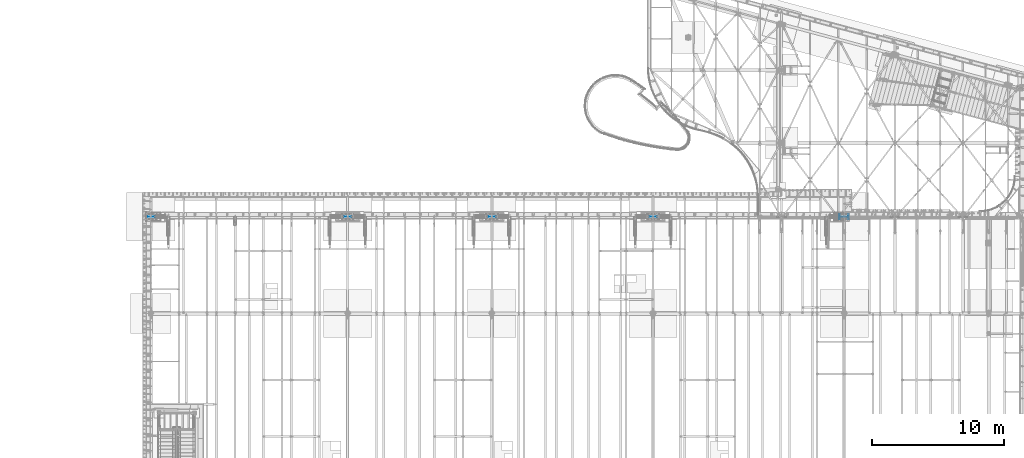
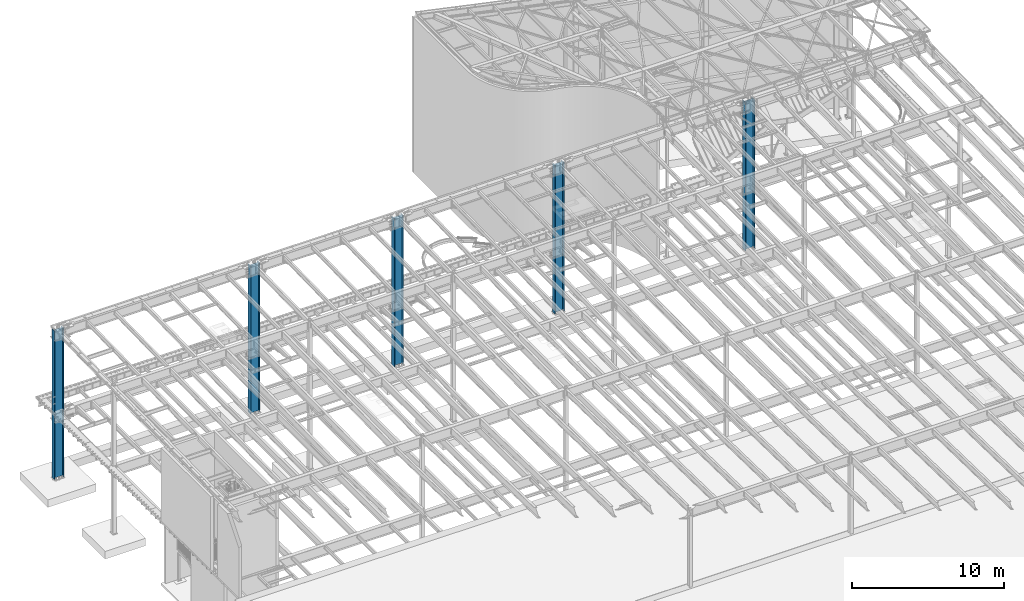
# One storey, part 913 of 1763: 5 columns, 5 elements without a shape of their own.
"""IFC2X3 building model written with IfcOpenShell, lengths in millimetres."""

from ifc_helpers import new_model, si_unit, frame, origin_with_axes, place, context, subcontext, project, spatial, faceted_brep, material, type_object, element, aggregate, save


model = new_model("IFC2X3")

# Units and contexts
model_context = context("Model", 3, precision=1e-05, world=origin_with_axes())
body_context = subcontext(model_context, "Body", "Model", "MODEL_VIEW")
ifc_project = project(units=[si_unit("LENGTHUNIT", "METRE", prefix="MILLI"), si_unit("AREAUNIT", "SQUARE_METRE"), si_unit("VOLUMEUNIT", "CUBIC_METRE"), si_unit("MASSUNIT", "GRAM", prefix="KILO"), si_unit("TIMEUNIT", "SECOND"), si_unit("PLANEANGLEUNIT", "RADIAN"), si_unit("SOLIDANGLEUNIT", "STERADIAN"), si_unit("THERMODYNAMICTEMPERATUREUNIT", "DEGREE_CELSIUS"), si_unit("LUMINOUSINTENSITYUNIT", "LUMEN")], contexts=[model_context])

# Site, building, storey
site_placement = place(None, origin_with_axes())
site = spatial("IfcSite", under=ifc_project, at=site_placement, CompositionType="ELEMENT")
building_placement = place(site_placement, origin_with_axes())
building = spatial("IfcBuilding", under=site, at=building_placement, Name="Undefined", CompositionType="ELEMENT")
storey_placement = place(building_placement, origin_with_axes())
storey = spatial("IfcBuildingStorey", under=building, at=storey_placement, Name="Undefined", CompositionType="ELEMENT", Elevation=0.0)

# Assembly, column
assembly_1_placement = place(storey_placement, origin_with_axes())
assembly_1 = element("IfcElementAssembly", 1, at=assembly_1_placement, inside=storey, Name="COLUMN", AssemblyPlace="NOTDEFINED", PredefinedType="RIGID_FRAME")
ifc_material = material(Name="STEEL/A992")
column_type = type_object("IfcColumnType", Name="W27X194", PredefinedType="NOTDEFINED")
column_1_placement = place(assembly_1_placement, frame((-34949.8372736984, 52120.8, -304.8), z_axis=(-1.0, 0.0, 0.0), x_axis=(0.0, 0.0, 1.0)))
column_1 = element("IfcColumn", 2, at=column_1_placement, type_object=column_type, material=ifc_material, Name="COLUMN", ObjectType="W27X194", context=body_context, shape_type="Brep", body=[
    faceted_brep([(12023.7249917654, -177.800000000003, 357.1875), (12023.7249917654, -177.800000000003, 323.849999999999), (12023.7249917654, -9.52500000000146, 323.850000002378), (12023.7249917654, -9.52500000000146, -323.849999999999), (12023.7249917654, -177.800000000003, -323.849999999999), (12023.7249917654, -177.800000000003, -357.1875), (12023.7249917654, 177.800000000003, -357.1875), (12023.7249917654, 177.800000000003, -323.849999999999), (12023.7249917654, 9.52500000000146, -323.849999999999), (12023.7249917654, 9.52500000000146, 323.849999999999), (12023.7249917654, 177.800000000003, 323.849999999999), (12023.7249917654, 177.800000000003, 357.1875), (88.9000000000026, 177.800000000003, -323.849999999999), (108.14741549571, 177.800000000003, -357.1875), (108.147415495711, -177.800000000003, -357.1875), (88.9000000000026, -177.800000000003, -323.849999999999), (88.9000000000026, -9.52500000000146, -323.849999999999), (88.9000000000026, 9.52500000000146, -323.849999999999), (133.350001510695, -9.52500000000146, -323.849999999999), (133.350001510695, 9.52500000000146, -323.849999999999), (133.350001231294, -9.52500000000146, -311.149997345012), (133.350001231294, 9.52500000000146, -311.149997345012), (131.416541172274, -9.52500000000146, -301.429838351462), (131.416541172274, 9.52500000000146, -301.429838351462), (125.91051319003, -9.52500000000146, -293.189485536299), (125.91051319003, 9.52500000000146, -293.189485536299), (117.670160132589, -9.52500000000146, -287.683457916653), (117.670160132589, 9.52500000000146, -287.683457916653), (107.950001053962, -9.52500000000146, -285.749998285348), (107.950001053962, 9.52500000000146, -285.749998285348), (88.9000000000026, 9.52500000000146, -285.749998704494), (107.949999754769, -9.52500000000146, 285.749998704487), (88.9000000000026, 9.52500000000146, 285.749998704487), (107.950001892185, 9.52500000000146, 285.749998704487), (117.670160928276, -9.52500000000146, 287.683458549662), (117.670160928276, 9.52500000000146, 287.683458549662), (125.910513864584, -9.52500000000146, 293.189486350617), (125.910513864584, 9.52500000000146, 293.189486350617), (131.41654166554, -9.52500000000146, 301.429839286924), (131.41654166554, 9.52500000000146, 301.429839286924), (133.350001510715, -9.52500000000146, 311.149998323017), (133.350001510715, 9.52500000000146, 311.149998323017), (133.350001510715, -9.52500000000146, 323.850000993305), (133.350001510715, 9.52500000000146, 323.849999999999), (88.9000000000026, -9.52500000000146, 323.849999999999), (88.9000000000026, 9.52500000000146, 323.849999999999), (88.9000000000026, -177.800000000003, 323.849999999999), (108.147415495711, -177.800000000003, 357.1875), (108.14741549571, 177.800000000003, 357.1875), (88.9000000000026, 177.800000000003, 323.849999999999), (133.350001510715, 177.800000000003, 323.849999999999), (133.350001510695, 177.800000000003, -323.849999999999), (133.350001510695, -177.800000000003, -323.849999999999), (133.350001510715, -177.800000000003, 323.849999999999)], [[[0, 1, 2, 3, 4, 5, 6, 7, 8, 9, 10, 11]], [[12, 13, 14, 15, 16, 17]], [[18, 19, 17, 16]], [[20, 21, 19, 18]], [[22, 23, 21, 20]], [[24, 25, 23, 22]], [[26, 27, 25, 24]], [[28, 29, 27, 26]], [[29, 28, 30]], [[31, 32, 30, 28]], [[33, 32, 31]], [[34, 35, 33, 31]], [[36, 37, 35, 34]], [[38, 39, 37, 36]], [[40, 41, 39, 38]], [[42, 43, 41, 40]], [[44, 45, 43, 42]], [[46, 47, 48, 49, 45, 44]], [[48, 47, 0, 11]], [[50, 49, 48, 11, 10]], [[43, 45, 49, 50, 10, 9]], [[19, 21, 23, 25, 27, 29, 30, 32, 33, 35, 37, 39, 41, 43, 9, 8]], [[51, 12, 17, 19, 8, 7]], [[13, 12, 51, 7, 6]], [[14, 13, 6, 5]], [[52, 15, 14, 5, 4]], [[18, 16, 15, 52, 4, 3]], [[42, 40, 38, 36, 34, 31, 28, 26, 24, 22, 20, 18, 3, 2]], [[53, 46, 44, 42, 2, 1]], [[47, 46, 53, 1, 0]]]),
])
aggregate(assembly_1, [column_1])

assembly_2_placement = place(storey_placement, origin_with_axes())
assembly_2 = element("IfcElementAssembly", 3, at=assembly_2_placement, inside=storey, Name="COLUMN", AssemblyPlace="NOTDEFINED", PredefinedType="RIGID_FRAME")
column_2_placement = place(assembly_2_placement, frame((-49402.4372736984, 52120.8, -304.8), z_axis=(-1.0, 0.0, 0.0), x_axis=(0.0, 0.0, 1.0)))
column_2 = element("IfcColumn", 4, at=column_2_placement, type_object=column_type, material=ifc_material, Name="COLUMN", ObjectType="W27X194", context=body_context, shape_type="Brep", body=[
    faceted_brep([(12023.7249917654, -177.800000000003, 357.1875), (12023.7249917654, -177.800000000003, 323.849999999999), (12023.7249917654, -9.52500000000146, 323.850000002378), (12023.7249917654, -9.52500000000146, -323.849999999999), (12023.7249917654, -177.800000000003, -323.849999999999), (12023.7249917654, -177.800000000003, -357.1875), (12023.7249917654, 177.800000000003, -357.1875), (12023.7249917654, 177.800000000003, -323.849999999999), (12023.7249917654, 9.52500000000146, -323.849999999999), (12023.7249917654, 9.52500000000146, 323.849999999999), (12023.7249917654, 177.800000000003, 323.849999999999), (12023.7249917654, 177.800000000003, 357.1875), (88.9000000000026, 177.800000000003, -323.849999999999), (108.14741549571, 177.800000000003, -357.1875), (108.147415495711, -177.800000000003, -357.1875), (88.9000000000026, -177.800000000003, -323.849999999999), (88.9000000000026, -9.52500000000146, -323.849999999999), (88.9000000000026, 9.52500000000146, -323.849999999999), (133.350001510695, -9.52500000000146, -323.849999999999), (133.350001510695, 9.52500000000146, -323.849999999999), (133.350001231294, -9.52500000000146, -311.149997345012), (133.350001231294, 9.52500000000146, -311.149997345012), (131.416541172274, -9.52500000000146, -301.429838351462), (131.416541172274, 9.52500000000146, -301.429838351462), (125.91051319003, -9.52500000000146, -293.189485536299), (125.91051319003, 9.52500000000146, -293.189485536299), (117.670160132589, -9.52500000000146, -287.683457916653), (117.670160132589, 9.52500000000146, -287.683457916653), (107.950001053962, -9.52500000000146, -285.749998285348), (107.950001053962, 9.52500000000146, -285.749998285348), (88.9000000000026, 9.52500000000146, -285.749998704494), (107.949999754769, -9.52500000000146, 285.749998704487), (88.9000000000026, 9.52500000000146, 285.749998704487), (107.950001892185, 9.52500000000146, 285.749998704487), (117.670160928276, -9.52500000000146, 287.683458549662), (117.670160928276, 9.52500000000146, 287.683458549662), (125.910513864584, -9.52500000000146, 293.189486350617), (125.910513864584, 9.52500000000146, 293.189486350617), (131.41654166554, -9.52500000000146, 301.429839286924), (131.41654166554, 9.52500000000146, 301.429839286924), (133.350001510715, -9.52500000000146, 311.149998323017), (133.350001510715, 9.52500000000146, 311.149998323017), (133.350001510715, -9.52500000000146, 323.850000993305), (133.350001510715, 9.52500000000146, 323.849999999999), (88.9000000000026, -9.52500000000146, 323.849999999999), (88.9000000000026, 9.52500000000146, 323.849999999999), (88.9000000000026, -177.800000000003, 323.849999999999), (108.147415495711, -177.800000000003, 357.1875), (108.14741549571, 177.800000000003, 357.1875), (88.9000000000026, 177.800000000003, 323.849999999999), (133.350001510715, 177.800000000003, 323.849999999999), (133.350001510695, 177.800000000003, -323.849999999999), (133.350001510695, -177.800000000003, -323.849999999999), (133.350001510715, -177.800000000003, 323.849999999999)], [[[0, 1, 2, 3, 4, 5, 6, 7, 8, 9, 10, 11]], [[12, 13, 14, 15, 16, 17]], [[18, 19, 17, 16]], [[20, 21, 19, 18]], [[22, 23, 21, 20]], [[24, 25, 23, 22]], [[26, 27, 25, 24]], [[28, 29, 27, 26]], [[29, 28, 30]], [[31, 32, 30, 28]], [[33, 32, 31]], [[34, 35, 33, 31]], [[36, 37, 35, 34]], [[38, 39, 37, 36]], [[40, 41, 39, 38]], [[42, 43, 41, 40]], [[44, 45, 43, 42]], [[46, 47, 48, 49, 45, 44]], [[48, 47, 0, 11]], [[50, 49, 48, 11, 10]], [[43, 45, 49, 50, 10, 9]], [[19, 21, 23, 25, 27, 29, 30, 32, 33, 35, 37, 39, 41, 43, 9, 8]], [[51, 12, 17, 19, 8, 7]], [[13, 12, 51, 7, 6]], [[14, 13, 6, 5]], [[52, 15, 14, 5, 4]], [[18, 16, 15, 52, 4, 3]], [[42, 40, 38, 36, 34, 31, 28, 26, 24, 22, 20, 18, 3, 2]], [[53, 46, 44, 42, 2, 1]], [[47, 46, 53, 1, 0]]]),
])
aggregate(assembly_2, [column_2])

assembly_3_placement = place(storey_placement, origin_with_axes())
assembly_3 = element("IfcElementAssembly", 5, at=assembly_3_placement, inside=storey, Name="COLUMN", AssemblyPlace="NOTDEFINED", PredefinedType="RIGID_FRAME")
column_3_placement = place(assembly_3_placement, frame((-61594.4372736983, 52120.8, -304.8), z_axis=(-1.0, 0.0, 0.0), x_axis=(0.0, 0.0, 1.0)))
column_3 = element("IfcColumn", 6, at=column_3_placement, type_object=column_type, material=ifc_material, Name="COLUMN", ObjectType="W27X194", context=body_context, shape_type="Brep", body=[
    faceted_brep([(12023.7249917654, -177.800000000003, 357.1875), (12023.7249917654, -177.800000000003, 323.849999999999), (12023.7249917654, -9.52500000000146, 323.850000002378), (12023.7249917654, -9.52500000000146, -323.849999999999), (12023.7249917654, -177.800000000003, -323.849999999999), (12023.7249917654, -177.800000000003, -357.1875), (12023.7249917654, 177.800000000003, -357.1875), (12023.7249917654, 177.800000000003, -323.849999999999), (12023.7249917654, 9.52500000000146, -323.849999999999), (12023.7249917654, 9.52500000000146, 323.849999999999), (12023.7249917654, 177.800000000003, 323.849999999999), (12023.7249917654, 177.800000000003, 357.1875), (88.9000000000026, 177.800000000003, -323.849999999999), (108.14741549571, 177.800000000003, -357.1875), (108.147415495711, -177.800000000003, -357.1875), (88.9000000000026, -177.800000000003, -323.849999999999), (88.9000000000026, -9.52500000000146, -323.849999999999), (88.9000000000026, 9.52500000000146, -323.849999999999), (133.350001510695, -9.52500000000146, -323.849999999999), (133.350001510695, 9.52500000000146, -323.849999999999), (133.350001231294, -9.52500000000146, -311.149997345012), (133.350001231294, 9.52500000000146, -311.149997345012), (131.416541172274, -9.52500000000146, -301.429838351462), (131.416541172274, 9.52500000000146, -301.429838351462), (125.91051319003, -9.52500000000146, -293.189485536299), (125.91051319003, 9.52500000000146, -293.189485536299), (117.670160132589, -9.52500000000146, -287.683457916653), (117.670160132589, 9.52500000000146, -287.683457916653), (107.950001053962, -9.52500000000146, -285.749998285348), (107.950001053962, 9.52500000000146, -285.749998285348), (88.9000000000026, 9.52500000000146, -285.749998704494), (107.949999754769, -9.52500000000146, 285.749998704487), (88.9000000000026, 9.52500000000146, 285.749998704487), (107.950001892185, 9.52500000000146, 285.749998704487), (117.670160928276, -9.52500000000146, 287.683458549662), (117.670160928276, 9.52500000000146, 287.683458549662), (125.910513864584, -9.52500000000146, 293.189486350617), (125.910513864584, 9.52500000000146, 293.189486350617), (131.41654166554, -9.52500000000146, 301.429839286924), (131.41654166554, 9.52500000000146, 301.429839286924), (133.350001510715, -9.52500000000146, 311.149998323017), (133.350001510715, 9.52500000000146, 311.149998323017), (133.350001510715, -9.52500000000146, 323.850000993305), (133.350001510715, 9.52500000000146, 323.849999999999), (88.9000000000026, -9.52500000000146, 323.849999999999), (88.9000000000026, 9.52500000000146, 323.849999999999), (88.9000000000026, -177.800000000003, 323.849999999999), (108.147415495711, -177.800000000003, 357.1875), (108.14741549571, 177.800000000003, 357.1875), (88.9000000000026, 177.800000000003, 323.849999999999), (133.350001510715, 177.800000000003, 323.849999999999), (133.350001510695, 177.800000000003, -323.849999999999), (133.350001510695, -177.800000000003, -323.849999999999), (133.350001510715, -177.800000000003, 323.849999999999)], [[[0, 1, 2, 3, 4, 5, 6, 7, 8, 9, 10, 11]], [[12, 13, 14, 15, 16, 17]], [[18, 19, 17, 16]], [[20, 21, 19, 18]], [[22, 23, 21, 20]], [[24, 25, 23, 22]], [[26, 27, 25, 24]], [[28, 29, 27, 26]], [[29, 28, 30]], [[31, 32, 30, 28]], [[33, 32, 31]], [[34, 35, 33, 31]], [[36, 37, 35, 34]], [[38, 39, 37, 36]], [[40, 41, 39, 38]], [[42, 43, 41, 40]], [[44, 45, 43, 42]], [[46, 47, 48, 49, 45, 44]], [[48, 47, 0, 11]], [[50, 49, 48, 11, 10]], [[43, 45, 49, 50, 10, 9]], [[19, 21, 23, 25, 27, 29, 30, 32, 33, 35, 37, 39, 41, 43, 9, 8]], [[51, 12, 17, 19, 8, 7]], [[13, 12, 51, 7, 6]], [[14, 13, 6, 5]], [[52, 15, 14, 5, 4]], [[18, 16, 15, 52, 4, 3]], [[42, 40, 38, 36, 34, 31, 28, 26, 24, 22, 20, 18, 3, 2]], [[53, 46, 44, 42, 2, 1]], [[47, 46, 53, 1, 0]]]),
])
aggregate(assembly_3, [column_3])

assembly_4_placement = place(storey_placement, origin_with_axes())
assembly_4 = element("IfcElementAssembly", 7, at=assembly_4_placement, inside=storey, Name="COLUMN", AssemblyPlace="NOTDEFINED", PredefinedType="RIGID_FRAME")
column_4_placement = place(assembly_4_placement, frame((-72491.0372736984, 52120.8, -304.8), z_axis=(-1.0, 0.0, 0.0), x_axis=(0.0, 0.0, 1.0)))
column_4 = element("IfcColumn", 8, at=column_4_placement, type_object=column_type, material=ifc_material, Name="COLUMN", ObjectType="W27X194", context=body_context, shape_type="Brep", body=[
    faceted_brep([(12023.7249917654, -177.800000000003, 357.1875), (12023.7249917654, -177.800000000003, 323.849999999999), (12023.7249917654, -9.52500000000146, 323.850000002378), (12023.7249917654, -9.52500000000146, -323.849999999999), (12023.7249917654, -177.800000000003, -323.849999999999), (12023.7249917654, -177.800000000003, -357.1875), (12023.7249917654, 177.800000000003, -357.1875), (12023.7249917654, 177.800000000003, -323.849999999999), (12023.7249917654, 9.52500000000146, -323.849999999999), (12023.7249917654, 9.52500000000146, 323.849999999999), (12023.7249917654, 177.800000000003, 323.849999999999), (12023.7249917654, 177.800000000003, 357.1875), (88.9000000000026, 177.800000000003, -323.849999999999), (108.14741549571, 177.800000000003, -357.1875), (108.147415495711, -177.800000000003, -357.1875), (88.9000000000026, -177.800000000003, -323.849999999999), (88.9000000000026, -9.52500000000146, -323.849999999999), (88.9000000000026, 9.52500000000146, -323.849999999999), (133.350001510695, -9.52500000000146, -323.849999999999), (133.350001510695, 9.52500000000146, -323.849999999999), (133.350001231294, -9.52500000000146, -311.149997345012), (133.350001231294, 9.52500000000146, -311.149997345012), (131.416541172274, -9.52500000000146, -301.429838351462), (131.416541172274, 9.52500000000146, -301.429838351462), (125.91051319003, -9.52500000000146, -293.189485536299), (125.91051319003, 9.52500000000146, -293.189485536299), (117.670160132589, -9.52500000000146, -287.683457916653), (117.670160132589, 9.52500000000146, -287.683457916653), (107.950001053962, -9.52500000000146, -285.749998285348), (107.950001053962, 9.52500000000146, -285.749998285348), (88.9000000000026, 9.52500000000146, -285.749998704494), (107.949999754769, -9.52500000000146, 285.749998704487), (88.9000000000026, 9.52500000000146, 285.749998704487), (107.950001892185, 9.52500000000146, 285.749998704487), (117.670160928276, -9.52500000000146, 287.683458549662), (117.670160928276, 9.52500000000146, 287.683458549662), (125.910513864584, -9.52500000000146, 293.189486350617), (125.910513864584, 9.52500000000146, 293.189486350617), (131.41654166554, -9.52500000000146, 301.429839286924), (131.41654166554, 9.52500000000146, 301.429839286924), (133.350001510715, -9.52500000000146, 311.149998323017), (133.350001510715, 9.52500000000146, 311.149998323017), (133.350001510715, -9.52500000000146, 323.850000993305), (133.350001510715, 9.52500000000146, 323.849999999999), (88.9000000000026, -9.52500000000146, 323.849999999999), (88.9000000000026, 9.52500000000146, 323.849999999999), (88.9000000000026, -177.800000000003, 323.849999999999), (108.147415495711, -177.800000000003, 357.1875), (108.14741549571, 177.800000000003, 357.1875), (88.9000000000026, 177.800000000003, 323.849999999999), (133.350001510715, 177.800000000003, 323.849999999999), (133.350001510695, 177.800000000003, -323.849999999999), (133.350001510695, -177.800000000003, -323.849999999999), (133.350001510715, -177.800000000003, 323.849999999999)], [[[0, 1, 2, 3, 4, 5, 6, 7, 8, 9, 10, 11]], [[12, 13, 14, 15, 16, 17]], [[18, 19, 17, 16]], [[20, 21, 19, 18]], [[22, 23, 21, 20]], [[24, 25, 23, 22]], [[26, 27, 25, 24]], [[28, 29, 27, 26]], [[29, 28, 30]], [[31, 32, 30, 28]], [[33, 32, 31]], [[34, 35, 33, 31]], [[36, 37, 35, 34]], [[38, 39, 37, 36]], [[40, 41, 39, 38]], [[42, 43, 41, 40]], [[44, 45, 43, 42]], [[46, 47, 48, 49, 45, 44]], [[48, 47, 0, 11]], [[50, 49, 48, 11, 10]], [[43, 45, 49, 50, 10, 9]], [[19, 21, 23, 25, 27, 29, 30, 32, 33, 35, 37, 39, 41, 43, 9, 8]], [[51, 12, 17, 19, 8, 7]], [[13, 12, 51, 7, 6]], [[14, 13, 6, 5]], [[52, 15, 14, 5, 4]], [[18, 16, 15, 52, 4, 3]], [[42, 40, 38, 36, 34, 31, 28, 26, 24, 22, 20, 18, 3, 2]], [[53, 46, 44, 42, 2, 1]], [[47, 46, 53, 1, 0]]]),
])
aggregate(assembly_4, [column_4])

assembly_5_placement = place(storey_placement, origin_with_axes())
assembly_5 = element("IfcElementAssembly", 9, at=assembly_5_placement, inside=storey, Name="COLUMN", AssemblyPlace="NOTDEFINED", PredefinedType="RIGID_FRAME")
column_5_placement = place(assembly_5_placement, frame((-87375.4372736983, 52120.8, -914.4), z_axis=(-1.0, 0.0, 0.0), x_axis=(0.0, 0.0, 1.0)))
column_5 = element("IfcColumn", 10, at=column_5_placement, type_object=column_type, material=ifc_material, Name="COLUMN", ObjectType="W27X194", context=body_context, shape_type="Brep", body=[
    faceted_brep([(12633.3249917654, -177.800000000003, 357.1875), (12633.3249917654, -177.800000000003, 323.850000000006), (12633.3249917654, -9.52500000000146, 323.850000002378), (12633.3249917654, -9.52500000000146, -323.850000000006), (12633.3249917654, -177.800000000003, -323.850000000006), (12633.3249917654, -177.800000000003, -357.1875), (12633.3249917654, 177.800000000003, -357.1875), (12633.3249917654, 177.800000000003, -323.850000000006), (12633.3249917654, 9.52500000000146, -323.850000000006), (12633.3249917654, 9.52500000000146, 323.850000000006), (12633.3249917654, 177.800000000003, 323.850000000006), (12633.3249917654, 177.800000000003, 357.1875), (698.499999999984, 177.800000000003, -323.850000000006), (717.747415495685, 177.800000000003, -357.1875), (717.747415495684, -177.800000000003, -357.1875), (698.499999999984, -177.800000000003, -323.850000000006), (698.499999999984, -9.52500000000146, -323.850000000006), (698.499999999984, 9.52500000000146, -323.850000000006), (742.950001510671, -9.52500000000146, -323.850000000006), (742.950001510671, 9.52500000000146, -323.850000000006), (742.950001231268, -9.52500000000146, -311.149997345012), (742.950001231268, 9.52500000000146, -311.149997345012), (741.016541172248, -9.52500000000146, -301.429838351454), (741.016541172248, 9.52500000000146, -301.429838351454), (735.510513190003, -9.52500000000146, -293.189485536292), (735.510513190003, 9.52500000000146, -293.189485536292), (727.270160132563, -9.52500000000146, -287.683457916646), (727.270160132563, 9.52500000000146, -287.683457916646), (717.550001053936, -9.52500000000146, -285.749998285333), (717.550001053936, 9.52500000000146, -285.749998285333), (698.499999999984, 9.52500000000146, -285.749998704487), (717.549999754742, -9.52500000000146, 285.749998704487), (698.499999999984, 9.52500000000146, 285.749998704487), (717.550001892159, 9.52500000000146, 285.749998704487), (727.27016092825, -9.52500000000146, 287.683458549669), (727.27016092825, 9.52500000000146, 287.683458549669), (735.510513864557, -9.52500000000146, 293.189486350617), (735.510513864557, 9.52500000000146, 293.189486350617), (741.016541665513, -9.52500000000146, 301.429839286924), (741.016541665513, 9.52500000000146, 301.429839286924), (742.950001510689, -9.52500000000146, 311.149998323017), (742.950001510689, 9.52500000000146, 311.149998323017), (742.950001510689, -9.52500000000146, 323.850000993305), (742.95000151069, 9.52500000000146, 323.850000000006), (698.499999999984, -9.52500000000146, 323.850000000006), (698.499999999984, 9.52500000000146, 323.850000000006), (698.499999999984, -177.800000000003, 323.850000000006), (717.747415495684, -177.800000000003, 357.1875), (717.747415495685, 177.800000000003, 357.1875), (698.499999999984, 177.800000000003, 323.850000000006), (742.95000151069, 177.800000000003, 323.850000000006), (742.950001510671, 177.800000000003, -323.850000000006), (742.950001510671, -177.800000000003, -323.850000000006), (742.95000151069, -177.800000000003, 323.850000000006)], [[[0, 1, 2, 3, 4, 5, 6, 7, 8, 9, 10, 11]], [[12, 13, 14, 15, 16, 17]], [[18, 19, 17, 16]], [[20, 21, 19, 18]], [[22, 23, 21, 20]], [[24, 25, 23, 22]], [[26, 27, 25, 24]], [[28, 29, 27, 26]], [[29, 28, 30]], [[31, 32, 30, 28]], [[33, 32, 31]], [[34, 35, 33, 31]], [[36, 37, 35, 34]], [[38, 39, 37, 36]], [[40, 41, 39, 38]], [[42, 43, 41, 40]], [[44, 45, 43, 42]], [[46, 47, 48, 49, 45, 44]], [[48, 47, 0, 11]], [[50, 49, 48, 11, 10]], [[43, 45, 49, 50, 10, 9]], [[19, 21, 23, 25, 27, 29, 30, 32, 33, 35, 37, 39, 41, 43, 9, 8]], [[51, 12, 17, 19, 8, 7]], [[13, 12, 51, 7, 6]], [[14, 13, 6, 5]], [[52, 15, 14, 5, 4]], [[18, 16, 15, 52, 4, 3]], [[42, 40, 38, 36, 34, 31, 28, 26, 24, 22, 20, 18, 3, 2]], [[53, 46, 44, 42, 2, 1]], [[47, 46, 53, 1, 0]]]),
])
aggregate(assembly_5, [column_5])

save(model, "model.ifc")
